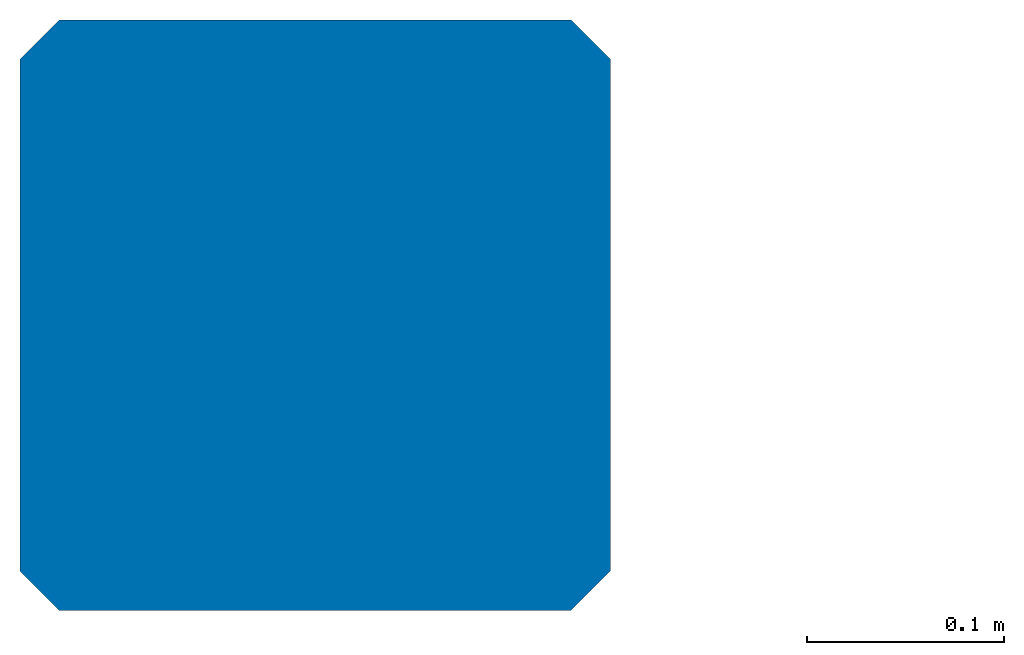
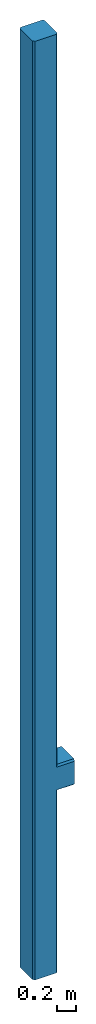
# One storey: 1 column.
"""IFC2X3 building model written with IfcOpenShell, lengths in metres."""

import ifcopenshell
import ifcopenshell.guid

model = None  # the IFC model being written
_history = None  # IfcOwnerHistory: only IFC2X3 demands one
_inside = {}  # id of a spatial element -> (the spatial element, [elements in it])
_under = {}  # id of a project, library or spatial element -> (it, [spatial elements below it])
_declared = {}  # id of a project -> (the project, [libraries it declares])
_typed = {}  # id of a type object -> (the type object, [elements of that type])
_made_of = {}  # id of a material, layer set ... -> (it, [elements and type objects made of it])


def new_model(schema):
    """Start an empty IFC model of exactly this schema.

    Asked for "IFC4X3", IfcOpenShell would pick the latest addendum, in which some entities
    have other attributes; the version numbers below select the first issue.
    IFC2X3 requires an IfcOwnerHistory on every rooted entity: one is made here for all.
    """
    global model, _history
    if schema == "IFC4X3":
        model = ifcopenshell.file(schema_version=(4, 3, 0, 0))
    else:
        model = ifcopenshell.file(schema=schema)
    _inside.clear()
    _under.clear()
    _declared.clear()
    _typed.clear()
    _made_of.clear()
    _history = None
    if model.schema == "IFC2X3":
        org = make("IfcOrganization", Name="unknown")
        user = make(
            "IfcPersonAndOrganization",
            ThePerson=make("IfcPerson", FamilyName="unknown"),
            TheOrganization=org,
        )
        app = make(
            "IfcApplication",
            ApplicationDeveloper=org,
            Version="unknown",
            ApplicationFullName="unknown",
            ApplicationIdentifier="unknown",
        )
        _history = make(
            "IfcOwnerHistory",
            OwningUser=user,
            OwningApplication=app,
            ChangeAction="ADDED",
            CreationDate=0,
        )
    return model


def make(cls, **values):
    """One entity of the class cls with the attributes given. An attribute that is None is left unset."""
    return model.create_entity(
        cls, **{name: value for name, value in values.items() if value is not None}
    )


def entity(cls, *values):
    """Any entity or typed value of the class cls, its attributes in the order of the schema. None: left unset."""
    e = model.create_entity(cls)
    for i, value in enumerate(values):
        if value is not None:
            e[i] = value
    return e


def rooted(cls, **values):
    """An entity with a GlobalId (a new one), such as an element, a storey or a relation."""
    return make(cls, GlobalId=ifcopenshell.guid.new(), OwnerHistory=_history, **values)


def si_unit(unit_type, name, prefix=None):
    """IfcSIUnit, for example si_unit("LENGTHUNIT", "METRE", prefix="MILLI")."""
    return make("IfcSIUnit", UnitType=unit_type, Prefix=prefix, Name=name)


def converted_unit(unit_type, name, factor, base, dimensions=None, offset=None):
    """IfcConversionBasedUnit, such as the inch: factor (a typed value) times the base unit."""
    return make(
        "IfcConversionBasedUnit"
        if offset is None
        else "IfcConversionBasedUnitWithOffset",
        ConversionOffset=offset,
        Dimensions=None
        if dimensions is None
        else entity("IfcDimensionalExponents", *dimensions),
        UnitType=unit_type,
        Name=name,
        ConversionFactor=make(
            "IfcMeasureWithUnit", ValueComponent=factor, UnitComponent=base
        ),
    )


def derived_unit(unit_type, elements):
    """IfcDerivedUnit: a product of units, each with its exponent."""
    return make(
        "IfcDerivedUnit",
        Elements=[
            make("IfcDerivedUnitElement", Unit=unit, Exponent=power)
            for unit, power in elements
        ],
        UnitType=unit_type,
    )


def assignment(units):
    """IfcUnitAssignment: the units of a project."""
    return None if units is None else make("IfcUnitAssignment", Units=units)


def point(xyz):
    """IfcCartesianPoint."""
    return None if xyz is None else make("IfcCartesianPoint", Coordinates=xyz)


def direction(xyz):
    """IfcDirection."""
    return None if xyz is None else make("IfcDirection", DirectionRatios=xyz)


def frame(location, z_axis=None, x_axis=None):
    """IfcAxis2Placement3D, a coordinate frame: its origin and axes. An axis left out is left unset."""
    return make(
        "IfcAxis2Placement3D",
        Location=point(location),
        Axis=direction(z_axis),
        RefDirection=direction(x_axis),
    )


def origin():
    """The frame at (0, 0, 0) with its axes left unset."""
    return frame((0.0, 0.0, 0.0))


def place(relative_to, where):
    """IfcLocalPlacement: puts the frame where relative to a parent placement (None: the world)."""
    return make(
        "IfcLocalPlacement", PlacementRelTo=relative_to, RelativePlacement=where
    )


def context(
    kind, dimensions, precision=None, world=None, true_north=None, identifier=None
):
    """IfcGeometricRepresentationContext, for example the 3D "Model" context."""
    return make(
        "IfcGeometricRepresentationContext",
        ContextIdentifier=identifier,
        ContextType=kind,
        CoordinateSpaceDimension=dimensions,
        Precision=precision,
        WorldCoordinateSystem=world,
        TrueNorth=true_north,
    )


def subcontext(parent, identifier, kind, view, scale=None):
    """IfcGeometricRepresentationSubContext, for example "Body" below "Model"."""
    return make(
        "IfcGeometricRepresentationSubContext",
        ContextIdentifier=identifier,
        ContextType=kind,
        ParentContext=parent,
        TargetScale=scale,
        TargetView=view,
    )


def project(units=None, contexts=None):
    """IfcProject with its units and contexts."""
    return rooted(
        "IfcProject",
        Name="project",
        RepresentationContexts=contexts,
        UnitsInContext=assignment(units),
    )


def spatial(cls, under=None, at=None, **own):
    """A site, building, storey or space (cls), placed at a placement, below another one or the project."""
    s = rooted(cls, ObjectPlacement=at, **own)
    if under is not None:
        _under.setdefault(under.id(), (under, []))[1].append(s)
    return s


def faces_of(points, faces, orient=None, outer=None):
    """IfcFace entities. A face is a list of loops; a loop is a list of indices into points, from 0.

    orient and outer hold one flag for each loop. By default every Orientation is true, the
    first loop of a face is its IfcFaceOuterBound and the others are IfcFaceBound.
    """
    made = []
    for i, loops in enumerate(faces):
        bounds = []
        for j, loop in enumerate(loops):
            is_outer = j == 0 if outer is None else outer[i][j]
            bounds.append(
                make(
                    "IfcFaceOuterBound" if is_outer else "IfcFaceBound",
                    Bound=make("IfcPolyLoop", Polygon=[points[k] for k in loop]),
                    Orientation=True if orient is None else orient[i][j],
                )
            )
        made.append(make("IfcFace", Bounds=bounds))
    return made


def faceted_brep(points, faces, orient=None, outer=None, voids=None):
    """IfcFacetedBrep: a solid bounded by flat faces; with voids (closed shells), ...WithVoids."""
    shared = [point(p) for p in points]
    hull = make("IfcClosedShell", CfsFaces=faces_of(shared, faces, orient, outer))
    if voids is None:
        return make("IfcFacetedBrep", Outer=hull)
    return make(
        "IfcFacetedBrepWithVoids",
        Outer=hull,
        Voids=[
            make(cls, CfsFaces=faces_of(shared, fs, o, b)) for cls, fs, o, b in voids
        ],
    )


def shape(context_of_items, identifier, shape_type, items):
    """IfcShapeRepresentation: the items that make up one representation, for example the "Body"."""
    return make(
        "IfcShapeRepresentation",
        ContextOfItems=context_of_items,
        RepresentationIdentifier=identifier,
        RepresentationType=shape_type,
        Items=items,
    )


def source(mapping_origin, context_of_items, identifier, shape_type, items):
    """IfcRepresentationMap: a shape defined once, which mapped items show again and again."""
    return make(
        "IfcRepresentationMap",
        MappingOrigin=mapping_origin,
        MappedRepresentation=shape(context_of_items, identifier, shape_type, items),
    )


def transform(
    local_origin,
    x_axis=None,
    y_axis=None,
    z_axis=None,
    scale=None,
    scale2=None,
    scale3=None,
    uniform=True,
):
    """IfcCartesianTransformationOperator3D, or its non-uniform kind. x_axis, y_axis, z_axis: its Axis1, 2, 3."""
    if uniform:
        return make(
            "IfcCartesianTransformationOperator3D",
            Axis1=direction(x_axis),
            Axis2=direction(y_axis),
            LocalOrigin=point(local_origin),
            Scale=scale,
            Axis3=direction(z_axis),
        )
    return make(
        "IfcCartesianTransformationOperator3DnonUniform",
        Axis1=direction(x_axis),
        Axis2=direction(y_axis),
        LocalOrigin=point(local_origin),
        Scale=scale,
        Axis3=direction(z_axis),
        Scale2=scale2,
        Scale3=scale3,
    )


def mapped(mapping_source, mapping_target):
    """IfcMappedItem: shows the shape of a source again, moved by a transform."""
    return make(
        "IfcMappedItem", MappingSource=mapping_source, MappingTarget=mapping_target
    )


def made_of(thing, what):
    """Note that an element or type object is made of a material, layer set ...; save() writes the relation."""
    if what is not None:
        _made_of.setdefault(what.id(), (what, []))[1].append(thing)
    return thing


def type_object(cls, material=None, **own):
    """A type object (cls), such as IfcWallType, which elements share."""
    return made_of(rooted(cls, **own), material)


def type_shapes(of_type, sources):
    """Give a type object the sources (RepresentationMaps) that its elements show as mapped items."""
    of_type.RepresentationMaps = sources


def element(
    cls,
    number,
    at=None,
    inside=None,
    cuts=None,
    type_object=None,
    material=None,
    context=None,
    identifier="Body",
    shape_type=None,
    held_by="IfcProductDefinitionShape",
    body=None,
    shapes=None,
    **own,
):
    """One element of the class cls, such as IfcWall. Its Tag is "e" and its number.

    at: its placement. inside: the storey or other place that contains it. cuts: it is an
    opening in that element (IfcRelVoidsElement). A single representation is given by context,
    identifier, shape_type and body (its items); several are given by shapes. held_by: the class
    of the entity that holds the representations. save() writes the other relations.
    """
    e = rooted(cls, Tag="e%d" % number, ObjectPlacement=at, **own)
    if body is not None:
        shapes = [shape(context, identifier, shape_type, body)]
    if shapes is not None:
        e.Representation = make(held_by, Representations=shapes)
    if inside is not None:
        _inside.setdefault(inside.id(), (inside, []))[1].append(e)
    if cuts is not None:
        rooted(
            "IfcRelVoidsElement", RelatingBuildingElement=cuts, RelatedOpeningElement=e
        )
    if type_object is not None:
        _typed.setdefault(type_object.id(), (type_object, []))[1].append(e)
    return made_of(e, material)


def aggregate(whole, parts):
    """IfcRelAggregates: a whole, such as a stair, and the parts it consists of."""
    return rooted("IfcRelAggregates", RelatingObject=whole, RelatedObjects=parts)


def save(model, path):
    """Write the relations noted so far, then the file.

    IfcRelAggregates (storeys below a building ...), IfcRelContainedInSpatialStructure (elements
    in a storey), IfcRelDefinesByType, IfcRelAssociatesMaterial and IfcRelDeclares: one each for
    every whole, place, type object, material and project.
    """
    for whole, parts in _under.values():
        aggregate(whole, parts)
    for where, things in _inside.values():
        rooted(
            "IfcRelContainedInSpatialStructure",
            RelatedElements=things,
            RelatingStructure=where,
        )
    for kind, things in _typed.values():
        rooted("IfcRelDefinesByType", RelatedObjects=things, RelatingType=kind)
    for what, things in _made_of.values():
        rooted("IfcRelAssociatesMaterial", RelatedObjects=things, RelatingMaterial=what)
    for by, libraries in _declared.values():
        rooted("IfcRelDeclares", RelatingContext=by, RelatedDefinitions=libraries)
    model.write(path)


model = new_model("IFC2X3")

# Units and contexts
model_context = context("Model", 3, precision=1e-05, world=origin(), true_north=direction((6.12303176911189e-17, 1.0)))
body_context = subcontext(model_context, "Body", "Model", "MODEL_VIEW")
ifc_project = project(units=[si_unit("LENGTHUNIT", "METRE"), converted_unit("AREAUNIT", "SQUARE FOOT", entity("IfcRatioMeasure", 0.09290304), si_unit("AREAUNIT", "SQUARE_METRE"), dimensions=[2, 0, 0, 0, 0, 0, 0]), converted_unit("VOLUMEUNIT", "CUBIC FOOT", entity("IfcRatioMeasure", 0.028316846592), si_unit("VOLUMEUNIT", "CUBIC_METRE"), dimensions=[3, 0, 0, 0, 0, 0, 0]), converted_unit("PLANEANGLEUNIT", "DEGREE", entity("IfcRatioMeasure", 0.0174532925199433), si_unit("PLANEANGLEUNIT", "RADIAN"), dimensions=[0, 0, 0, 0, 0, 0, 0]), si_unit("MASSUNIT", "GRAM", prefix="KILO"), derived_unit("MASSDENSITYUNIT", [(si_unit("MASSUNIT", "GRAM", prefix="KILO"), 1), (si_unit("LENGTHUNIT", "METRE"), -3)]), si_unit("TIMEUNIT", "SECOND"), si_unit("FREQUENCYUNIT", "HERTZ"), si_unit("THERMODYNAMICTEMPERATUREUNIT", "DEGREE_CELSIUS"), derived_unit("THERMALTRANSMITTANCEUNIT", [(si_unit("MASSUNIT", "GRAM", prefix="KILO"), 1), (si_unit("THERMODYNAMICTEMPERATUREUNIT", "KELVIN"), -1), (si_unit("TIMEUNIT", "SECOND"), -3)]), derived_unit("VOLUMETRICFLOWRATEUNIT", [(si_unit("LENGTHUNIT", "METRE"), 3), (si_unit("TIMEUNIT", "SECOND"), -1)]), si_unit("ELECTRICCURRENTUNIT", "AMPERE"), si_unit("ELECTRICVOLTAGEUNIT", "VOLT"), si_unit("POWERUNIT", "WATT"), si_unit("FORCEUNIT", "NEWTON"), si_unit("ILLUMINANCEUNIT", "LUX"), si_unit("LUMINOUSFLUXUNIT", "LUMEN"), si_unit("LUMINOUSINTENSITYUNIT", "CANDELA"), derived_unit("USERDEFINED", [(si_unit("MASSUNIT", "GRAM", prefix="KILO"), -1), (si_unit("LENGTHUNIT", "METRE"), -2), (si_unit("TIMEUNIT", "SECOND"), 3), (si_unit("LUMINOUSFLUXUNIT", "LUMEN"), 1)]), derived_unit("LINEARVELOCITYUNIT", [(si_unit("LENGTHUNIT", "METRE"), 1), (si_unit("TIMEUNIT", "SECOND"), -1)]), si_unit("PRESSUREUNIT", "PASCAL"), derived_unit("USERDEFINED", [(si_unit("LENGTHUNIT", "METRE"), -2), (si_unit("MASSUNIT", "GRAM", prefix="KILO"), 1), (si_unit("TIMEUNIT", "SECOND"), -2)])], contexts=[model_context])

# Site, building, storey
site_placement = place(None, origin())
site = spatial("IfcSite", under=ifc_project, at=site_placement, CompositionType="ELEMENT")
building_placement = place(site_placement, origin())
building = spatial("IfcBuilding", under=site, at=building_placement, CompositionType="ELEMENT")
storey_placement = place(building_placement, origin())
storey = spatial("IfcBuildingStorey", under=building, at=storey_placement, Name="Level 1", CompositionType="ELEMENT", Elevation=0.0)

# Column
column_type = type_object("IfcColumnType", Name="Structural Columns 1", PredefinedType="COLUMN")
shared_shape = source(origin(), body_context, "Body", "Brep", [
    faceted_brep([(0.28, 0.3, 12.0), (0.0200000000000014, 0.300000000000001, 12.0), (0.0, 0.28, 12.0), (0.0, 0.0200000000000009, 12.0), (0.0199999999999987, 0.0, 12.0), (0.28, 0.0, 12.0), (0.299999999999999, 0.0200000000000009, 12.0), (0.3, 0.28, 12.0), (0.28, 0.3, 0.0), (0.3, 0.28, 0.0), (0.299999999999999, 0.0200000000000009, 0.0), (0.28, 0.0, 0.0), (0.0199999999999987, 0.0, 0.0), (0.0, 0.0200000000000009, 0.0), (0.0, 0.28, 0.0), (0.0200000000000014, 0.300000000000001, 0.0), (0.28, 0.3, 2.63), (0.500000000000001, 0.3, 2.63), (0.500000000000001, 0.3, 2.34000000000001), (0.280000000000001, 0.3, 2.34000000000001), (0.28, 0.0, 2.34000000000001), (0.500000000000001, 0.0, 2.34000000000001), (0.500000000000001, 0.0, 2.63000000000001), (0.280000000000001, 0.0, 2.63000000000001), (0.3, 0.020000000000002, 2.65000000000001), (0.3, 0.28, 2.65), (0.500000000000001, 0.0200000000000009, 2.32000000000001), (0.500000000000001, 0.28, 2.32000000000001), (0.500000000000001, 0.28, 2.65), (0.500000000000001, 0.0200000000000009, 2.65000000000001), (0.299999999999999, 0.0200000000000009, 2.32000000000001), (0.3, 0.28, 2.32000000000001)], [[[0, 1, 2, 3, 4, 5, 6, 7]], [[8, 9, 10, 11, 12, 13, 14, 15]], [[1, 0, 16, 17, 18, 19, 8, 15]], [[2, 1, 15, 14]], [[3, 2, 14, 13]], [[4, 3, 13, 12]], [[5, 4, 12, 11, 20, 21, 22, 23]], [[6, 5, 23, 24]], [[7, 6, 24, 25]], [[0, 7, 25, 16]], [[22, 21, 26, 27, 18, 17, 28, 29]], [[26, 21, 20, 30]], [[27, 26, 30, 31]], [[18, 27, 31, 19]], [[28, 17, 16, 25]], [[29, 28, 25, 24]], [[22, 29, 24, 23]], [[9, 8, 19, 31]], [[10, 9, 31, 30]], [[11, 10, 30, 20]]]),
])
type_shapes(column_type, [shared_shape])
column_placement = place(storey_placement, frame((4.37897935776135, 8.92544198737147, 0.0)))
element("IfcColumn", 1, at=column_placement, inside=storey, type_object=column_type, Name="Structural Columns 1:Structural Columns 1", ObjectType="Structural Columns 1", context=body_context, shape_type="MappedRepresentation", body=[
    mapped(shared_shape, transform((0.0, 0.0, 0.0), scale=1.0)),
])

save(model, "model.ifc")
